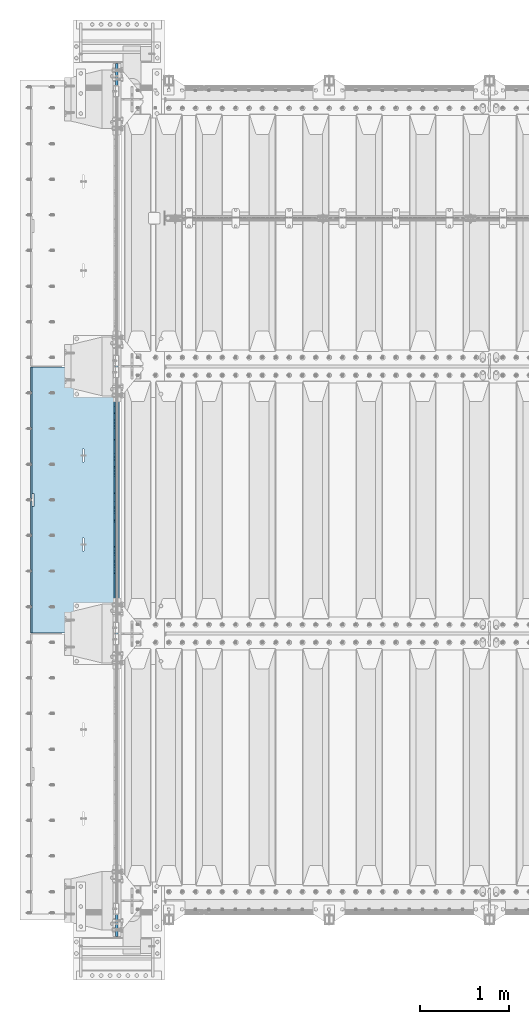
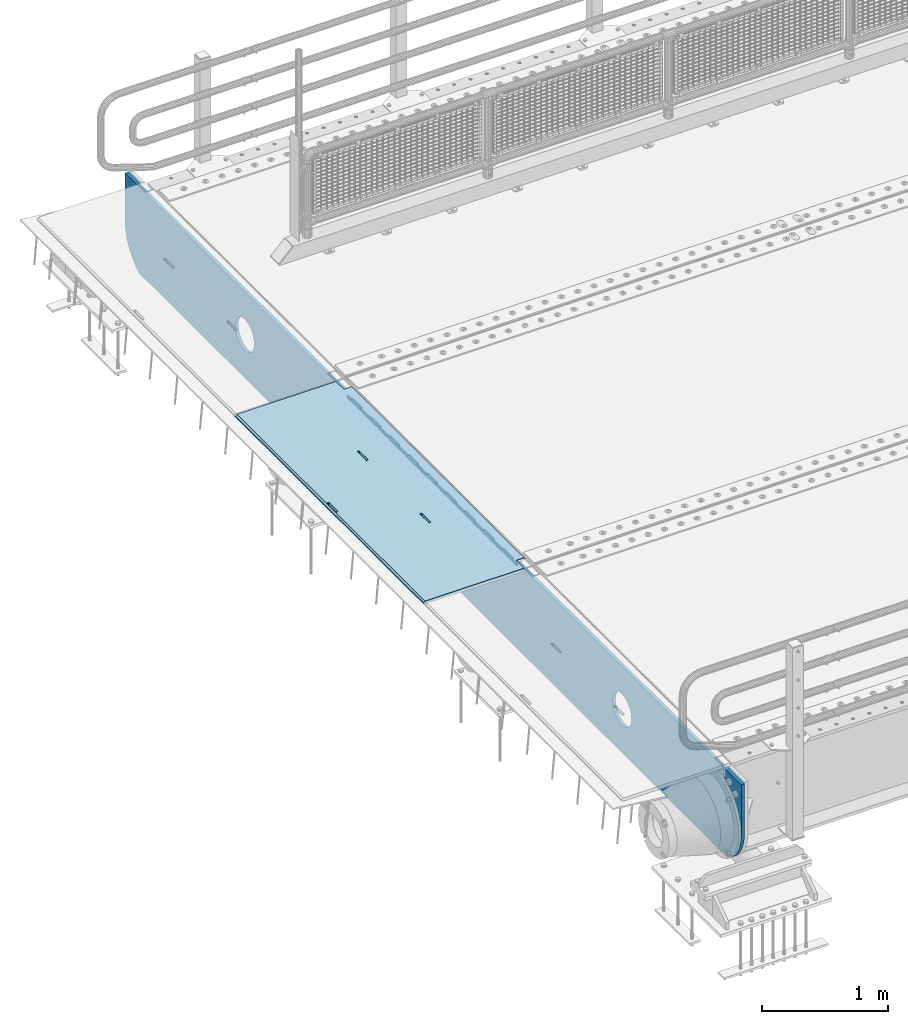
# One storey, part 170 of 219: 3 plates.
"""IFC2X3 building model written with IfcOpenShell, lengths in millimetres."""

import ifcopenshell
import ifcopenshell.guid

model = None  # the IFC model being written
_history = None  # IfcOwnerHistory: only IFC2X3 demands one
_inside = {}  # id of a spatial element -> (the spatial element, [elements in it])
_under = {}  # id of a project, library or spatial element -> (it, [spatial elements below it])
_declared = {}  # id of a project -> (the project, [libraries it declares])
_typed = {}  # id of a type object -> (the type object, [elements of that type])
_made_of = {}  # id of a material, layer set ... -> (it, [elements and type objects made of it])


def new_model(schema):
    """Start an empty IFC model of exactly this schema.

    Asked for "IFC4X3", IfcOpenShell would pick the latest addendum, in which some entities
    have other attributes; the version numbers below select the first issue.
    IFC2X3 requires an IfcOwnerHistory on every rooted entity: one is made here for all.
    """
    global model, _history
    if schema == "IFC4X3":
        model = ifcopenshell.file(schema_version=(4, 3, 0, 0))
    else:
        model = ifcopenshell.file(schema=schema)
    _inside.clear()
    _under.clear()
    _declared.clear()
    _typed.clear()
    _made_of.clear()
    _history = None
    if model.schema == "IFC2X3":
        org = make("IfcOrganization", Name="unknown")
        user = make(
            "IfcPersonAndOrganization",
            ThePerson=make("IfcPerson", FamilyName="unknown"),
            TheOrganization=org,
        )
        app = make(
            "IfcApplication",
            ApplicationDeveloper=org,
            Version="unknown",
            ApplicationFullName="unknown",
            ApplicationIdentifier="unknown",
        )
        _history = make(
            "IfcOwnerHistory",
            OwningUser=user,
            OwningApplication=app,
            ChangeAction="ADDED",
            CreationDate=0,
        )
    return model


def make(cls, **values):
    """One entity of the class cls with the attributes given. An attribute that is None is left unset."""
    return model.create_entity(
        cls, **{name: value for name, value in values.items() if value is not None}
    )


def rooted(cls, **values):
    """An entity with a GlobalId (a new one), such as an element, a storey or a relation."""
    return make(cls, GlobalId=ifcopenshell.guid.new(), OwnerHistory=_history, **values)


def si_unit(unit_type, name, prefix=None):
    """IfcSIUnit, for example si_unit("LENGTHUNIT", "METRE", prefix="MILLI")."""
    return make("IfcSIUnit", UnitType=unit_type, Prefix=prefix, Name=name)


def assignment(units):
    """IfcUnitAssignment: the units of a project."""
    return None if units is None else make("IfcUnitAssignment", Units=units)


def point(xyz):
    """IfcCartesianPoint."""
    return None if xyz is None else make("IfcCartesianPoint", Coordinates=xyz)


def direction(xyz):
    """IfcDirection."""
    return None if xyz is None else make("IfcDirection", DirectionRatios=xyz)


def frame(location, z_axis=None, x_axis=None):
    """IfcAxis2Placement3D, a coordinate frame: its origin and axes. An axis left out is left unset."""
    return make(
        "IfcAxis2Placement3D",
        Location=point(location),
        Axis=direction(z_axis),
        RefDirection=direction(x_axis),
    )


def origin_with_axes():
    """The frame at (0, 0, 0) with the z axis (0, 0, 1) and the x axis (1, 0, 0) written out."""
    return frame((0.0, 0.0, 0.0), z_axis=(0.0, 0.0, 1.0), x_axis=(1.0, 0.0, 0.0))


def place(relative_to, where):
    """IfcLocalPlacement: puts the frame where relative to a parent placement (None: the world)."""
    return make(
        "IfcLocalPlacement", PlacementRelTo=relative_to, RelativePlacement=where
    )


def context(
    kind, dimensions, precision=None, world=None, true_north=None, identifier=None
):
    """IfcGeometricRepresentationContext, for example the 3D "Model" context."""
    return make(
        "IfcGeometricRepresentationContext",
        ContextIdentifier=identifier,
        ContextType=kind,
        CoordinateSpaceDimension=dimensions,
        Precision=precision,
        WorldCoordinateSystem=world,
        TrueNorth=true_north,
    )


def subcontext(parent, identifier, kind, view, scale=None):
    """IfcGeometricRepresentationSubContext, for example "Body" below "Model"."""
    return make(
        "IfcGeometricRepresentationSubContext",
        ContextIdentifier=identifier,
        ContextType=kind,
        ParentContext=parent,
        TargetScale=scale,
        TargetView=view,
    )


def project(units=None, contexts=None):
    """IfcProject with its units and contexts."""
    return rooted(
        "IfcProject",
        Name="project",
        RepresentationContexts=contexts,
        UnitsInContext=assignment(units),
    )


def spatial(cls, under=None, at=None, **own):
    """A site, building, storey or space (cls), placed at a placement, below another one or the project."""
    s = rooted(cls, ObjectPlacement=at, **own)
    if under is not None:
        _under.setdefault(under.id(), (under, []))[1].append(s)
    return s


def faces_of(points, faces, orient=None, outer=None):
    """IfcFace entities. A face is a list of loops; a loop is a list of indices into points, from 0.

    orient and outer hold one flag for each loop. By default every Orientation is true, the
    first loop of a face is its IfcFaceOuterBound and the others are IfcFaceBound.
    """
    made = []
    for i, loops in enumerate(faces):
        bounds = []
        for j, loop in enumerate(loops):
            is_outer = j == 0 if outer is None else outer[i][j]
            bounds.append(
                make(
                    "IfcFaceOuterBound" if is_outer else "IfcFaceBound",
                    Bound=make("IfcPolyLoop", Polygon=[points[k] for k in loop]),
                    Orientation=True if orient is None else orient[i][j],
                )
            )
        made.append(make("IfcFace", Bounds=bounds))
    return made


def faceted_brep(points, faces, orient=None, outer=None, voids=None):
    """IfcFacetedBrep: a solid bounded by flat faces; with voids (closed shells), ...WithVoids."""
    shared = [point(p) for p in points]
    hull = make("IfcClosedShell", CfsFaces=faces_of(shared, faces, orient, outer))
    if voids is None:
        return make("IfcFacetedBrep", Outer=hull)
    return make(
        "IfcFacetedBrepWithVoids",
        Outer=hull,
        Voids=[
            make(cls, CfsFaces=faces_of(shared, fs, o, b)) for cls, fs, o, b in voids
        ],
    )


def shape(context_of_items, identifier, shape_type, items):
    """IfcShapeRepresentation: the items that make up one representation, for example the "Body"."""
    return make(
        "IfcShapeRepresentation",
        ContextOfItems=context_of_items,
        RepresentationIdentifier=identifier,
        RepresentationType=shape_type,
        Items=items,
    )


def material(Name=None, Category=None):
    """IfcMaterial."""
    return make("IfcMaterial", Name=Name, Category=Category)


def made_of(thing, what):
    """Note that an element or type object is made of a material, layer set ...; save() writes the relation."""
    if what is not None:
        _made_of.setdefault(what.id(), (what, []))[1].append(thing)
    return thing


def type_object(cls, material=None, **own):
    """A type object (cls), such as IfcWallType, which elements share."""
    return made_of(rooted(cls, **own), material)


def element(
    cls,
    number,
    at=None,
    inside=None,
    cuts=None,
    type_object=None,
    material=None,
    context=None,
    identifier="Body",
    shape_type=None,
    held_by="IfcProductDefinitionShape",
    body=None,
    shapes=None,
    **own,
):
    """One element of the class cls, such as IfcWall. Its Tag is "e" and its number.

    at: its placement. inside: the storey or other place that contains it. cuts: it is an
    opening in that element (IfcRelVoidsElement). A single representation is given by context,
    identifier, shape_type and body (its items); several are given by shapes. held_by: the class
    of the entity that holds the representations. save() writes the other relations.
    """
    e = rooted(cls, Tag="e%d" % number, ObjectPlacement=at, **own)
    if body is not None:
        shapes = [shape(context, identifier, shape_type, body)]
    if shapes is not None:
        e.Representation = make(held_by, Representations=shapes)
    if inside is not None:
        _inside.setdefault(inside.id(), (inside, []))[1].append(e)
    if cuts is not None:
        rooted(
            "IfcRelVoidsElement", RelatingBuildingElement=cuts, RelatedOpeningElement=e
        )
    if type_object is not None:
        _typed.setdefault(type_object.id(), (type_object, []))[1].append(e)
    return made_of(e, material)


def aggregate(whole, parts):
    """IfcRelAggregates: a whole, such as a stair, and the parts it consists of."""
    return rooted("IfcRelAggregates", RelatingObject=whole, RelatedObjects=parts)


def save(model, path):
    """Write the relations noted so far, then the file.

    IfcRelAggregates (storeys below a building ...), IfcRelContainedInSpatialStructure (elements
    in a storey), IfcRelDefinesByType, IfcRelAssociatesMaterial and IfcRelDeclares: one each for
    every whole, place, type object, material and project.
    """
    for whole, parts in _under.values():
        aggregate(whole, parts)
    for where, things in _inside.values():
        rooted(
            "IfcRelContainedInSpatialStructure",
            RelatedElements=things,
            RelatingStructure=where,
        )
    for kind, things in _typed.values():
        rooted("IfcRelDefinesByType", RelatedObjects=things, RelatingType=kind)
    for what, things in _made_of.values():
        rooted("IfcRelAssociatesMaterial", RelatedObjects=things, RelatingMaterial=what)
    for by, libraries in _declared.values():
        rooted("IfcRelDeclares", RelatingContext=by, RelatedDefinitions=libraries)
    model.write(path)


model = new_model("IFC2X3")

# Units and contexts
model_context = context("Model", 3, precision=1e-05, world=origin_with_axes())
body_context = subcontext(model_context, "Body", "Model", "MODEL_VIEW")
ifc_project = project(units=[si_unit("LENGTHUNIT", "METRE", prefix="MILLI"), si_unit("AREAUNIT", "SQUARE_METRE"), si_unit("VOLUMEUNIT", "CUBIC_METRE"), si_unit("MASSUNIT", "GRAM", prefix="KILO"), si_unit("TIMEUNIT", "SECOND"), si_unit("PLANEANGLEUNIT", "RADIAN"), si_unit("SOLIDANGLEUNIT", "STERADIAN"), si_unit("THERMODYNAMICTEMPERATUREUNIT", "DEGREE_CELSIUS"), si_unit("LUMINOUSINTENSITYUNIT", "LUMEN")], contexts=[model_context])

# Site, building, storey
site_placement = place(None, origin_with_axes())
site = spatial("IfcSite", under=ifc_project, at=site_placement, CompositionType="ELEMENT")
building_placement = place(site_placement, origin_with_axes())
building = spatial("IfcBuilding", under=site, at=building_placement, Name="Standard", CompositionType="ELEMENT")
storey_placement = place(building_placement, origin_with_axes())
storey = spatial("IfcBuildingStorey", under=building, at=storey_placement, Name="Undefined", CompositionType="ELEMENT", Elevation=0.0)

# Plates
ifc_material = material(Name="STEEL/S355N")
plate_type_1 = type_object("IfcPlateType", PredefinedType="NOTDEFINED")
plate_1_placement = place(storey_placement, frame((-57.5, 29845.0000994083, -36.0014545213866), z_axis=(0.0, -0.999999999987744, -4.95099999993769e-06), x_axis=(0.0, 4.95100000930963e-06, -0.999999999987744)))
element("IfcPlate", 1, at=plate_1_placement, inside=storey, type_object=plate_type_1, material=ifc_material, context=body_context, shape_type="Brep", body=[
    faceted_brep([(0.0, -7.49999999999999, 0.0), (-1.24849464100407e-10, -7.5, 70.0000000000036), (-1.24849464100407e-10, 7.5, 70.0000000000036), (0.0, 7.5, 0.0), (-14.9899997711175, -7.5, 70.0000000000036), (-14.9899997711175, 7.5, 70.0000000000036), (-14.9899997711161, -7.5, 220.0), (-14.9899997711161, 7.5, 220.0), (-3.90834031804843e-10, -7.5, 220.000000000004), (-3.90834031804843e-10, 7.5, 220.000000000004), (-6.56818599509279e-10, -7.5, 370.0), (-6.56818599509279e-10, 7.5, 370.0), (-14.9899997711147, -7.5, 370.000000000004), (-14.9899997711147, 7.5, 370.000000000004), (-14.9899997711133, -7.5, 520.000000000004), (-14.9899997711133, 7.5, 520.000000000004), (-9.24629262044618e-10, -7.5, 520.000000000004), (-9.24629262044618e-10, 7.5, 520.000000000004), (-1.1906067243217e-09, -7.5, 670.000000000004), (-1.1906067243217e-09, 7.5, 670.000000000004), (-14.9899997711119, -7.5, 670.0), (-14.9899997711119, 7.5, 670.0), (-14.9899997711105, -7.5, 820.000000000004), (-14.9899997711105, 7.5, 820.000000000004), (-1.45477940804994e-09, -7.5, 820.0), (-1.45477940804994e-09, 7.5, 820.0), (-1.72257585973057e-09, -7.5, 970.000000000004), (-1.72257585973057e-09, 7.5, 970.000000000004), (-14.9899997711091, -7.5, 970.000000000004), (-14.9899997711091, 7.5, 970.000000000004), (-14.9899997711077, -7.5, 1120.0), (-14.9899997711077, 7.5, 1120.0), (-1.98856753286236e-09, -7.5, 1120.0), (-1.98856753286236e-09, 7.5, 1120.0), (-2.2545521005668e-09, -7.5, 1270.0), (-2.2545521005668e-09, 7.5, 1270.0), (-14.9899997711063, -7.5, 1270.0), (-14.9899997711063, 7.5, 1270.0), (-14.9899997711049, -7.5, 1420.0), (-14.9899997711049, 7.5, 1420.0), (-2.52235565767478e-09, -7.5, 1420.0), (-2.52235565767478e-09, 7.5, 1420.0), (-2.78834733080657e-09, -7.5, 1570.0), (-2.78834733080657e-09, 7.5, 1570.0), (-14.9899997711034, -7.5, 1570.0), (-14.9899997711034, 7.5, 1570.0), (-14.989999771102, -7.5, 1720.0), (-14.989999771102, 7.5, 1720.0), (-3.05433189851101e-09, -7.5, 1720.0), (-3.05433189851101e-09, 7.5, 1720.0), (-3.32212835019163e-09, -7.5, 1870.0), (-3.32212835019163e-09, 7.5, 1870.0), (-14.9899997711006, -7.5, 1870.0), (-14.9899997711006, 7.5, 1870.0), (-14.9899997710992, -7.5, 2020.0), (-14.9899997710992, 7.5, 2020.0), (-3.58812002332343e-09, -7.5, 2020.0), (-3.58812002332343e-09, 7.5, 2020.0), (-3.85410459102786e-09, -7.5, 2170.0), (-3.85410459102786e-09, 7.5, 2170.0), (-14.9899997710978, -7.5, 2170.0), (-14.9899997710978, 7.5, 2170.0), (-14.9899997710964, -7.5, 2320.0), (-14.9899997710964, 7.5, 2320.0), (-4.12190814813584e-09, -7.5, 2320.0), (-4.12190814813584e-09, 7.5, 2320.0), (-4.38789271584028e-09, -7.5, 2470.0), (-4.38789271584028e-09, 7.5, 2470.0), (-14.9999999999768, -7.5, 2470.0), (-14.9999999999768, 7.5, 2470.0), (-14.9899997710936, -7.5, 2620.0), (-14.9899997710936, 7.5, 2620.0), (-4.65388438897207e-09, -7.5, 2620.0), (-4.65388438897207e-09, 7.5, 2620.0), (-4.77873385307248e-09, -7.5, 2690.0), (-4.77873385307248e-09, 7.5, 2690.0), (25.0100002289071, -7.5, 2690.0), (25.0100002289071, 7.5, 2690.0), (25.0, -7.49999999999999, 0.0), (25.0, 7.5, 0.0)], [[[0, 1, 2, 3]], [[1, 4, 5, 2]], [[4, 6, 7, 5]], [[6, 8, 9, 7]], [[8, 10, 11, 9]], [[10, 12, 13, 11]], [[12, 14, 15, 13]], [[14, 16, 17, 15]], [[16, 18, 19, 17]], [[18, 20, 21, 19]], [[20, 22, 23, 21]], [[22, 24, 25, 23]], [[24, 26, 27, 25]], [[26, 28, 29, 27]], [[28, 30, 31, 29]], [[30, 32, 33, 31]], [[32, 34, 35, 33]], [[34, 36, 37, 35]], [[36, 38, 39, 37]], [[38, 40, 41, 39]], [[40, 42, 43, 41]], [[42, 44, 45, 43]], [[44, 46, 47, 45]], [[46, 48, 49, 47]], [[48, 50, 51, 49]], [[50, 52, 53, 51]], [[52, 54, 55, 53]], [[54, 56, 57, 55]], [[56, 58, 59, 57]], [[58, 60, 61, 59]], [[60, 62, 63, 61]], [[62, 64, 65, 63]], [[64, 66, 67, 65]], [[66, 68, 69, 67]], [[68, 70, 71, 69]], [[70, 72, 73, 71]], [[72, 74, 75, 73]], [[74, 76, 77, 75]], [[76, 78, 79, 77]], [[78, 0, 3, 79]], [[5, 7, 9, 11, 13, 15, 17, 19, 21, 23, 25, 27, 29, 31, 33, 35, 37, 39, 41, 43, 45, 47, 49, 51, 53, 55, 57, 59, 61, 63, 65, 67, 69, 71, 73, 75, 77, 79, 3, 2]], [[78, 76, 74, 72, 70, 68, 66, 64, 62, 60, 58, 56, 54, 52, 50, 48, 46, 44, 42, 40, 38, 36, 34, 32, 30, 28, 26, 24, 22, 20, 18, 16, 14, 12, 10, 8, 6, 4, 1, 0]]]),
])
plate_type_2 = type_object("IfcPlateType", PredefinedType="NOTDEFINED")
plate_2_placement = place(storey_placement, frame((-5.00375433032989, 29994.9999261728, -1.00001208605641), z_axis=(0.0, -0.999999999987744, -4.95099999993769e-06), x_axis=(-0.999999999879068, -1.00000022172504e-09, -1.55519999981193e-05)))
element("IfcPlate", 2, at=plate_2_placement, inside=storey, type_object=plate_type_2, material=ifc_material, context=body_context, shape_type="Brep", body=[
    faceted_brep([(-0.000111589569153914, -5.71507077586908e-05, 2865.00000504128), (15.0002388791539, 15.0, 2865.00008049106), (15.000010422308, 15.0, 125.000079348178), (-0.000225737458036335, 5.71560140520955e-05, 125.000003632576), (999.996459960937, 4.99999999999999, 3.63797880709171e-12), (984.996459960937, 15.0, 3.63797880709171e-12), (984.996459730713, 15.0, 2990.0), (999.996459730713, 5.0, 2990.00000000001), (999.996459730713, -5.0, 2990.00000000001), (984.99645973052, -15.0, 2990.0), (984.996459961366, -15.0, 0.0), (999.996459960937, -5.0, 3.63797880709171e-12), (959.999522276416, -15.0000000031848, 1560.00000000859), (959.999522276416, 15.0, 1560.00000000859), (960.488957113226, 15.0, 1563.09016995233), (960.488957113226, -15.0000000031888, 1563.09016995234), (961.909352332213, 15.0, 1565.87785253151), (961.909352332213, -15.0000000032008, 1565.87785253151), (964.121669752867, 15.0, 1568.09016995233), (964.121669752867, -15.0000000032195, 1568.09016995234), (966.909352331933, 15.0, 1569.51056517154), (966.909352331933, -15.0000000032433, 1569.51056517154), (969.999522275633, 15.0, 1570.00000000859), (969.999522275633, -15.0000000032698, 1570.00000000859), (973.089692219423, 15.0, 1569.51056517153), (973.089692219423, -15.0000000032963, 1569.51056517154), (975.877374798709, 15.0, 1568.09016995233), (975.877374798709, -15.0000000033202, 1568.09016995233), (978.089692219705, 15.0, 1565.87785253151), (978.089692219705, -15.0000000033393, 1565.87785253151), (979.51008743912, 15.0, 1563.09016995233), (979.51008743912, -15.0000000033517, 1563.09016995233), (979.999522276404, 15.0, 1560.00000000857), (979.999522276404, -15.0000000033561, 1560.00000000857), (979.999522286274, 15.0, 1430.00000000857), (979.999522286274, -15.0000000033655, 1430.00000000857), (979.510087449461, 15.0, 1426.90983006483), (979.510087449461, -15.0000000033615, 1426.90983006483), (978.089692230473, 15.0, 1424.12214748566), (978.089692230472, -15.0000000033495, 1424.12214748566), (975.877374809819, 15.0, 1421.90983006484), (975.877374809819, -15.0000000033307, 1421.90983006484), (973.089692230754, 15.0, 1420.48943484563), (973.089692230754, -15.0000000033069, 1420.48943484563), (969.999522287207, 15.0, 1420.00000000859), (969.999522287207, -15.0000000032805, 1420.00000000859), (966.90935234342, 15.0, 1420.48943484564), (966.90935234342, -15.000000003254, 1420.48943484564), (964.121669764135, 15.0, 1421.90983006484), (964.121669764135, -15.00000000323, 1421.90983006484), (961.90935234314, 15.0, 1424.12214748566), (961.90935234314, -15.0000000032109, 1424.12214748566), (960.488957123723, 15.0, 1426.90983006484), (960.488957123723, -15.0000000031986, 1426.90983006484), (959.999522286436, 15.0, 1430.00000000859), (959.999522286436, -15.0000000031942, 1430.00000000859), (-0.000461899023639134, -14.9999999925605, 124.999928197289), (-0.000462055621302859, -14.9999999889596, 2864.99992960658), (75.0002624101966, 15.0, 125.000080471753), (74.9997898801964, -15.0, 124.999929601756), (74.999782061445, -15.0, 0.0), (75.0002485914438, 15.0, 0.0), (75.0005015105598, 15.0, 2990.0), (75.0000289805597, -15.0, 2990.0), (75.000491135538, 15.0, 2865.00008054909), (75.0000186055379, -14.999999997918, 2864.99992967908), (395.488957121483, -15.0, 1926.90983006551), (395.488957121483, 15.0, 1926.90983006551), (394.999522284197, 15.0, 1930.00000000926), (394.999522284197, -15.0, 1930.00000000927), (396.9093523409, -15.0, 1924.12214748633), (396.9093523409, 15.0, 1924.12214748634), (399.121669761895, -15.0, 1921.90983006551), (399.121669761895, 15.0, 1921.90983006551), (401.90935234118, -15.0, 1920.48943484631), (401.90935234118, 15.0, 1920.48943484631), (404.999522284967, -15.0, 1920.00000000926), (404.999522284967, 15.0, 1920.00000000926), (408.089692228539, -15.0, 1920.48943484631), (408.089692228539, 15.0, 1920.48943484631), (410.877374807603, -15.0, 1921.90983006551), (410.877374807603, 15.0, 1921.90983006551), (413.089692228257, -15.0, 1924.12214748633), (413.089692228257, 15.0, 1924.12214748633), (414.510087447246, -15.0, 1926.90983006551), (414.510087447246, 15.0, 1926.9098300655), (414.999522284058, -15.0, 1930.00000000926), (414.999522284058, 15.0, 1930.00000000925), (414.999522274167, -15.0, 2060.00000000926), (414.999522274167, 15.0, 2060.00000000925), (414.510087436882, -15.0, 2063.090169953), (414.510087436882, 15.0, 2063.090169953), (413.089692217466, -15.0, 2065.87785253218), (413.089692217466, 15.0, 2065.87785253218), (410.877374796471, -15.0, 2068.09016995301), (410.877374796471, 15.0, 2068.09016995301), (408.089692217185, -15.0, 2069.51056517222), (408.089692217185, 15.0, 2069.51056517222), (404.999522273396, -15.0, 2070.00000000926), (404.999522273396, 15.0, 2070.00000000926), (401.909352329694, -15.0, 2069.51056517222), (401.909352329694, 15.0, 2069.51056517221), (399.121669750628, -15.0, 2068.09016995301), (399.121669750628, 15.0, 2068.09016995302), (396.909352329974, -15.0, 2065.87785253219), (396.909352329974, 15.0, 2065.87785253219), (395.488957110987, -15.0, 2063.09016995301), (395.488957110987, 15.0, 2063.09016995301), (394.999522274176, -15.0, 2060.00000000927), (394.999522274176, 15.0, 2060.00000000926), (395.48895718799, -15.0, 1063.09016995166), (396.909352406977, -15.0, 1065.87785253083), (399.121669827631, -15.0, 1068.09016995166), (401.909352406696, -15.0, 1069.51056517086), (404.999522350398, -15.0, 1070.00000000791), (408.089692294187, -15.0, 1069.51056517087), (410.877374873474, -15.0, 1068.09016995166), (413.08969229447, -15.0, 1065.87785253083), (414.510087513886, -15.0, 1063.09016995165), (414.99952235117, -15.0, 1060.0000000079), (414.999522361062, -15.0, 930.000000007905), (414.510087524249, -15.0, 926.909830064156), (413.089692305261, -15.0, 924.122147484984), (410.877374884607, -15.0, 921.90983006416), (408.089692305543, -15.0, 920.489434844963), (404.999522361971, -15.0, 920.000000007909), (401.909352418184, -15.0, 920.489434844963), (399.121669838899, -15.0, 921.90983006416), (396.909352417904, -15.0, 924.122147484984), (395.488957198487, -15.0, 926.90983006416), (394.9995223612, -15.0, 930.000000007916), (394.99952235118, -15.0, 1060.00000000791), (396.909352417904, 15.0, 924.122147484988), (395.488957198487, 15.0, 926.90983006416), (399.121669838899, 15.0, 921.909830064164), (401.909352418184, 15.0, 920.48943484496), (404.999522361971, 15.0, 920.000000007905), (408.089692305543, 15.0, 920.48943484496), (410.877374884607, 15.0, 921.90983006416), (413.089692305261, 15.0, 924.122147484981), (414.510087524249, 15.0, 926.909830064153), (414.999522361062, 15.0, 930.000000007902), (414.99952235117, 15.0, 1060.0000000079), (414.510087513886, 15.0, 1063.09016995165), (413.08969229447, 15.0, 1065.87785253083), (410.877374873474, 15.0, 1068.09016995166), (408.089692294187, 15.0, 1069.51056517086), (404.999522350398, 15.0, 1070.00000000791), (401.909352406696, 15.0, 1069.51056517086), (399.121669827631, 15.0, 1068.09016995166), (396.909352406977, 15.0, 1065.87785253083), (395.48895718799, 15.0, 1063.09016995165), (394.99952235118, 15.0, 1060.00000000791), (394.9995223612, 15.0, 930.000000007913)], [[[0, 1, 2, 3]], [[4, 5, 6, 7]], [[8, 9, 10, 11]], [[12, 13, 14, 15]], [[15, 14, 16, 17]], [[17, 16, 18, 19]], [[19, 18, 20, 21]], [[21, 20, 22, 23]], [[23, 22, 24, 25]], [[25, 24, 26, 27]], [[27, 26, 28, 29]], [[29, 28, 30, 31]], [[31, 30, 32, 33]], [[33, 32, 34, 35]], [[35, 34, 36, 37]], [[37, 36, 38, 39]], [[39, 38, 40, 41]], [[41, 40, 42, 43]], [[43, 42, 44, 45]], [[45, 44, 46, 47]], [[47, 46, 48, 49]], [[49, 48, 50, 51]], [[51, 50, 52, 53]], [[53, 52, 54, 55]], [[55, 54, 13, 12]], [[56, 57, 0, 3]], [[58, 59, 56, 3, 2]], [[60, 59, 58, 61]], [[11, 10, 60, 61, 5, 4]], [[8, 11, 4, 7]], [[62, 63, 9, 8, 7, 6]], [[63, 62, 64, 65]], [[57, 65, 64, 1, 0]], [[66, 67, 68, 69]], [[70, 71, 67, 66]], [[72, 73, 71, 70]], [[74, 75, 73, 72]], [[76, 77, 75, 74]], [[78, 79, 77, 76]], [[80, 81, 79, 78]], [[82, 83, 81, 80]], [[84, 85, 83, 82]], [[86, 87, 85, 84]], [[88, 89, 87, 86]], [[90, 91, 89, 88]], [[92, 93, 91, 90]], [[94, 95, 93, 92]], [[96, 97, 95, 94]], [[98, 99, 97, 96]], [[100, 101, 99, 98]], [[102, 103, 101, 100]], [[104, 105, 103, 102]], [[106, 107, 105, 104]], [[108, 109, 107, 106]], [[69, 68, 109, 108]], [[63, 65, 57, 56, 59, 60, 10, 9], [15, 17, 19, 21, 23, 25, 27, 29, 31, 33, 35, 37, 39, 41, 43, 45, 47, 49, 51, 53, 55, 12], [110, 111, 112, 113, 114, 115, 116, 117, 118, 119, 120, 121, 122, 123, 124, 125, 126, 127, 128, 129, 130, 131], [106, 104, 102, 100, 98, 96, 94, 92, 90, 88, 86, 84, 82, 80, 78, 76, 74, 72, 70, 66, 69, 108]], [[128, 132, 133, 129]], [[127, 134, 132, 128]], [[126, 135, 134, 127]], [[125, 136, 135, 126]], [[124, 137, 136, 125]], [[123, 138, 137, 124]], [[122, 139, 138, 123]], [[121, 140, 139, 122]], [[120, 141, 140, 121]], [[119, 142, 141, 120]], [[118, 143, 142, 119]], [[117, 144, 143, 118]], [[116, 145, 144, 117]], [[115, 146, 145, 116]], [[114, 147, 146, 115]], [[113, 148, 147, 114]], [[112, 149, 148, 113]], [[111, 150, 149, 112]], [[110, 151, 150, 111]], [[131, 152, 151, 110]], [[130, 153, 152, 131]], [[129, 133, 153, 130]], [[64, 62, 6, 5, 61, 58, 2, 1], [50, 48, 46, 44, 42, 40, 38, 36, 34, 32, 30, 28, 26, 24, 22, 20, 18, 16, 14, 13, 54, 52], [132, 134, 135, 136, 137, 138, 139, 140, 141, 142, 143, 144, 145, 146, 147, 148, 149, 150, 151, 152, 153, 133], [71, 73, 75, 77, 79, 81, 83, 85, 87, 89, 91, 93, 95, 97, 99, 101, 103, 105, 107, 109, 68, 67]]]),
])
plate_type_3 = type_object("IfcPlateType", PredefinedType="NOTDEFINED")
plate_3_placement = place(storey_placement, frame((-35.0, 23600.0, -36.0000011217838), z_axis=(0.0, 1.0, 0.0), x_axis=(0.0, 0.0, -1.0)))
element("IfcPlate", 3, at=plate_3_placement, inside=storey, type_object=plate_type_3, material=ifc_material, context=body_context, shape_type="Brep", body=[
    faceted_brep([(449.263564598338, -15.0, 2047.11778936561), (449.263564598338, 15.0, 2047.11778936561), (477.402531099467, 15.0, 2038.58192701299), (477.402531099467, -15.0, 2038.58192701299), (503.335551114475, 15.0, 2024.72043882608), (503.335551114475, -15.0, 2024.72043882608), (526.06603322759, 15.0, 2006.06601402229), (526.06603322759, -15.0, 2006.06601402229), (544.720457758607, 15.0, 1983.33553168533), (544.720457758607, -15.0, 1983.33553168533), (558.58194563432, 15.0, 1957.40251150398), (558.58194563432, -15.0, 1957.40251150398), (567.117807649278, 15.0, 1929.26354490042), (567.117807649278, -15.0, 1929.26354490042), (570.000015413212, 15.0, 1899.99999658071), (570.000015413212, -15.0, 1899.99999658071), (567.117807298115, 15.0, 1870.73644829558), (567.117807298115, -15.0, 1870.73644829558), (558.581944945489, 15.0, 1842.59748179446), (558.581944945489, -15.0, 1842.59748179446), (544.72045675858, 15.0, 1816.66446177944), (544.72045675858, -15.0, 1816.66446177944), (526.066031954798, 15.0, 1793.93397966633), (526.066031954798, -15.0, 1793.93397966633), (503.335549617829, 15.0, 1775.27955513532), (503.335549617829, -15.0, 1775.27955513532), (477.402529436484, 15.0, 1761.4180672596), (477.402529436484, -15.0, 1761.4180672596), (449.263562832924, 15.0, 1752.88220524464), (449.263562832924, -15.0, 1752.88220524464), (420.000014513212, 15.0, 1749.99999748071), (420.000014513212, -15.0, 1749.99999748071), (390.736466228086, 15.0, 1752.8822055958), (390.736466228086, -15.0, 1752.8822055958), (362.597499726957, 15.0, 1761.41806794843), (362.597499726957, -15.0, 1761.41806794843), (336.664479711949, 15.0, 1775.27955613534), (336.664479711949, -15.0, 1775.27955613534), (313.933997598833, 15.0, 1793.93398093912), (313.933997598833, -15.0, 1793.93398093912), (295.279573067817, 15.0, 1816.66446327609), (295.279573067817, -15.0, 1816.66446327609), (281.418085192103, 15.0, 1842.59748345744), (281.418085192103, -15.0, 1842.59748345744), (272.882223177146, 15.0, 1870.73645006099), (272.882223177146, -15.0, 1870.73645006099), (270.000015413212, 15.0, 1899.99999838071), (270.000015413212, -15.0, 1899.99999838071), (272.882223528308, 15.0, 1929.26354666584), (272.882223528308, -15.0, 1929.26354666584), (281.418085880934, 15.0, 1957.40251316696), (281.418085880934, -15.0, 1957.40251316696), (295.279574067843, 15.0, 1983.33553318197), (295.279574067843, -15.0, 1983.33553318197), (313.933998871626, 15.0, 2006.06601529508), (313.933998871626, -15.0, 2006.06601529508), (336.664481208594, 15.0, 2024.7204398261), (336.664481208594, -15.0, 2024.7204398261), (362.59750138994, 15.0, 2038.58192770182), (362.59750138994, -15.0, 2038.58192770182), (390.736467993499, 15.0, 2047.11778971678), (390.736467993499, -15.0, 2047.11778971678), (420.000016313212, 15.0, 2049.99999748071), (420.000016313212, -15.0, 2049.99999748071), (-1.00212931641863e-06, 15.0, 9800.0), (-1.00212931641863e-06, -15.0, 9800.0), (479.000057668268, -15.0, 9799.99999712676), (479.000057638257, 15.0, 9800.0), (0.0, -15.0, 0.0), (0.0, 15.0, 0.0), (478.999999998661, 15.0, 3.63797880709171e-12), (478.999999998661, -15.0, 3.63797880709171e-12), (527.214672103509, 15.0, 2.91645036353293), (527.214672103509, -15.0, 2.91645036353293), (574.726265715988, 15.0, 11.623273032008), (574.726265715988, -15.0, 11.623273032008), (620.841954817566, 15.0, 25.9935029279113), (620.841954817566, -15.0, 25.9935029279113), (664.889268817663, 15.0, 45.8175897404326), (664.889268817663, -15.0, 45.8175897404326), (706.225898692239, 15.0, 70.8064536438796), (706.225898692239, -15.0, 70.8064536438796), (744.249063295727, 15.0, 100.59570073252), (744.249063295727, -15.0, 100.59570073252), (778.404299267498, 15.0, 134.750936704255), (778.404299267498, -15.0, 134.750936704255), (808.193546356196, 15.0, 172.774101307714), (808.193546356196, -15.0, 172.774101307714), (833.182410259716, 15.0, 214.110731182285), (833.182410259716, -15.0, 214.110731182285), (838.999998585997, -15.0, 227.036882190067), (838.999998585997, 15.0, 227.036882190067), (838.999940378862, 15.0, 9572.9632660323), (838.999940378862, -15.0, 9572.96326609896), (833.182425747838, 15.0, 9585.88925446581), (833.182425777838, -15.0, 9585.88925446581), (808.193562516767, 15.0, 9627.22588611668), (808.193562546767, -15.0, 9627.22588611668), (778.404315769945, 15.0, 9665.24905247718), (778.404315799945, -15.0, 9665.24905247718), (744.24907982555, 15.0, 9699.40429013417), (744.24907985555, -15.0, 9699.40429013417), (706.225914958721, 15.0, 9729.19353878752), (706.225914988721, -15.0, 9729.19353878752), (664.88928456082, 15.0, 9754.18240409127), (664.88928459082, -15.0, 9754.18240409127), (620.841969814272, 15.0, 9774.00649210158), (620.841969844272, -15.0, 9774.00649210158), (574.726279785182, 15.0, 9788.37672296127), (574.726279815182, -15.0, 9788.37672296127), (527.214685110275, 15.0, 9797.0835463353), (527.214685140275, -15.0, 9797.0835463353), (390.736498855293, -15.0, 8047.11778971678), (390.736498855293, 15.0, 8047.11778971678), (420.000047175005, 15.0, 8049.99999748071), (420.000047175005, -15.0, 8049.99999748071), (362.597532251734, -15.0, 8038.58192770182), (362.597532251734, 15.0, 8038.58192770182), (336.664512070388, -15.0, 8024.7204398261), (336.664512070388, 15.0, 8024.7204398261), (313.934029733419, -15.0, 8006.06601529508), (313.934029733419, 15.0, 8006.06601529508), (295.279604929637, -15.0, 7983.33553318197), (295.279604929637, 15.0, 7983.33553318197), (281.418116742727, -15.0, 7957.40251316696), (281.418116742727, 15.0, 7957.40251316696), (272.882254390102, -15.0, 7929.26354666584), (272.882254390102, 15.0, 7929.26354666584), (270.000046275005, -15.0, 7899.99999838071), (270.000046275005, 15.0, 7899.99999838071), (272.88225403894, -15.0, 7870.73645006099), (272.88225403894, 15.0, 7870.73645006099), (281.418116053897, -15.0, 7842.59748345744), (281.418116053897, 15.0, 7842.59748345744), (295.27960392961, -15.0, 7816.66446327609), (295.27960392961, 15.0, 7816.66446327609), (313.934028460627, -15.0, 7793.93398093912), (313.934028460627, 15.0, 7793.93398093912), (336.664510573743, -15.0, 7775.27955613534), (336.664510573743, 15.0, 7775.27955613534), (362.59753058875, -15.0, 7761.41806794843), (362.59753058875, 15.0, 7761.41806794843), (390.736497089879, -15.0, 7752.8822055958), (390.736497089879, 15.0, 7752.8822055958), (420.000045375005, -15.0, 7749.99999748071), (420.000045375005, 15.0, 7749.99999748071), (449.263593694718, -15.0, 7752.88220524464), (449.263593694718, 15.0, 7752.88220524464), (477.402560298277, -15.0, 7761.4180672596), (477.402560298277, 15.0, 7761.4180672596), (503.335580479623, -15.0, 7775.27955513532), (503.335580479623, 15.0, 7775.27955513532), (526.066062816592, -15.0, 7793.93397966633), (526.066062816592, 15.0, 7793.93397966633), (544.720487620374, -15.0, 7816.66446177944), (544.720487620374, 15.0, 7816.66446177944), (558.581975807283, -15.0, 7842.59748179446), (558.581975807283, 15.0, 7842.59748179446), (567.117838159909, -15.0, 7870.73644829558), (567.117838159909, 15.0, 7870.73644829558), (570.000046275006, -15.0, 7899.99999658071), (570.000046275006, 15.0, 7899.99999658071), (567.117838511071, -15.0, 7929.26354490042), (567.117838511071, 15.0, 7929.26354490042), (558.581976496114, -15.0, 7957.40251150398), (558.581976496114, 15.0, 7957.40251150398), (544.7204886204, -15.0, 7983.33553168533), (544.7204886204, 15.0, 7983.33553168533), (526.066064089384, -15.0, 8006.06601402229), (526.066064089384, 15.0, 8006.06601402229), (503.335581976268, -15.0, 8024.72043882608), (503.335581976268, 15.0, 8024.72043882608), (477.40256196126, -15.0, 8038.58192701299), (477.40256196126, 15.0, 8038.58192701299), (449.263595460131, -15.0, 8047.11778936561), (449.263595460131, 15.0, 8047.11778936561), (477.402546523754, -15.0, 5038.58192701299), (503.335566538762, -15.0, 5024.72043882608), (526.066048651878, -15.0, 5006.06601402229), (544.720473182894, -15.0, 4983.33553168533), (558.581961058607, -15.0, 4957.40251150398), (567.117823073565, -15.0, 4929.26354490042), (570.000030837499, -15.0, 4899.99999658071), (567.117822722403, -15.0, 4870.73644829558), (558.581960369777, -15.0, 4842.59748179446), (544.720472182868, -15.0, 4816.66446177944), (526.066047379085, -15.0, 4793.93397966633), (503.335565042117, -15.0, 4775.27955513532), (477.402544860771, -15.0, 4761.4180672596), (449.263578257212, -15.0, 4752.88220524464), (420.000029937499, -15.0, 4749.99999748071), (390.736481652373, -15.0, 4752.8822055958), (362.597515151244, -15.0, 4761.41806794843), (336.664495136236, -15.0, 4775.27955613534), (313.934013023121, -15.0, 4793.93398093912), (295.279588492104, -15.0, 4816.66446327609), (281.418100616391, -15.0, 4842.59748345744), (272.882238601433, -15.0, 4870.73645006099), (270.000030837499, -15.0, 4899.99999838071), (272.882238952596, -15.0, 4929.26354666584), (281.418101305221, -15.0, 4957.40251316696), (295.279589492131, -15.0, 4983.33553318197), (313.934014295913, -15.0, 5006.06601529508), (336.664496632882, -15.0, 5024.7204398261), (362.597516814228, -15.0, 5038.58192770182), (390.736483417787, -15.0, 5047.11778971678), (420.000031737499, -15.0, 5049.99999748071), (449.263580022625, -15.0, 5047.11778936561), (362.597516814228, 15.0, 5038.58192770182), (390.736483417787, 15.0, 5047.11778971678), (336.664496632882, 15.0, 5024.7204398261), (313.934014295913, 15.0, 5006.06601529508), (295.279589492131, 15.0, 4983.33553318197), (281.418101305221, 15.0, 4957.40251316696), (272.882238952596, 15.0, 4929.26354666584), (270.000030837499, 15.0, 4899.99999838071), (272.882238601433, 15.0, 4870.73645006099), (281.418100616391, 15.0, 4842.59748345744), (295.279588492104, 15.0, 4816.66446327609), (313.934013023121, 15.0, 4793.93398093912), (336.664495136236, 15.0, 4775.27955613534), (362.597515151244, 15.0, 4761.41806794843), (390.736481652373, 15.0, 4752.8822055958), (420.000029937499, 15.0, 4749.99999748071), (449.263578257212, 15.0, 4752.88220524464), (477.402544860771, 15.0, 4761.4180672596), (503.335565042117, 15.0, 4775.27955513532), (526.066047379085, 15.0, 4793.93397966633), (544.720472182868, 15.0, 4816.66446177944), (558.581960369777, 15.0, 4842.59748179446), (567.117822722403, 15.0, 4870.73644829558), (570.000030837499, 15.0, 4899.99999658071), (567.117823073565, 15.0, 4929.26354490042), (558.581961058607, 15.0, 4957.40251150398), (544.720473182894, 15.0, 4983.33553168533), (526.066048651878, 15.0, 5006.06601402229), (503.335566538762, 15.0, 5024.72043882608), (477.402546523754, 15.0, 5038.58192701299), (449.263580022625, 15.0, 5047.11778936561), (420.000031737499, 15.0, 5049.99999748071)], [[[0, 1, 2, 3]], [[3, 2, 4, 5]], [[5, 4, 6, 7]], [[7, 6, 8, 9]], [[9, 8, 10, 11]], [[11, 10, 12, 13]], [[13, 12, 14, 15]], [[15, 14, 16, 17]], [[17, 16, 18, 19]], [[19, 18, 20, 21]], [[21, 20, 22, 23]], [[23, 22, 24, 25]], [[25, 24, 26, 27]], [[27, 26, 28, 29]], [[29, 28, 30, 31]], [[31, 30, 32, 33]], [[33, 32, 34, 35]], [[35, 34, 36, 37]], [[37, 36, 38, 39]], [[39, 38, 40, 41]], [[41, 40, 42, 43]], [[43, 42, 44, 45]], [[45, 44, 46, 47]], [[47, 46, 48, 49]], [[49, 48, 50, 51]], [[51, 50, 52, 53]], [[53, 52, 54, 55]], [[55, 54, 56, 57]], [[57, 56, 58, 59]], [[59, 58, 60, 61]], [[61, 60, 62, 63]], [[63, 62, 1, 0]], [[64, 65, 66, 67]], [[68, 65, 64, 69]], [[68, 69, 70, 71]], [[71, 70, 72, 73]], [[73, 72, 74, 75]], [[75, 74, 76, 77]], [[77, 76, 78, 79]], [[79, 78, 80, 81]], [[81, 80, 82, 83]], [[83, 82, 84, 85]], [[85, 84, 86, 87]], [[87, 86, 88, 89]], [[90, 89, 88, 91]], [[90, 91, 92, 93]], [[93, 92, 94, 95]], [[95, 94, 96, 97]], [[97, 96, 98, 99]], [[99, 98, 100, 101]], [[101, 100, 102, 103]], [[103, 102, 104, 105]], [[105, 104, 106, 107]], [[107, 106, 108, 109]], [[109, 108, 110, 111]], [[66, 111, 110, 67]], [[112, 113, 114, 115]], [[116, 117, 113, 112]], [[118, 119, 117, 116]], [[120, 121, 119, 118]], [[122, 123, 121, 120]], [[124, 125, 123, 122]], [[126, 127, 125, 124]], [[128, 129, 127, 126]], [[130, 131, 129, 128]], [[132, 133, 131, 130]], [[134, 135, 133, 132]], [[136, 137, 135, 134]], [[138, 139, 137, 136]], [[140, 141, 139, 138]], [[142, 143, 141, 140]], [[144, 145, 143, 142]], [[146, 147, 145, 144]], [[148, 149, 147, 146]], [[150, 151, 149, 148]], [[152, 153, 151, 150]], [[154, 155, 153, 152]], [[156, 157, 155, 154]], [[158, 159, 157, 156]], [[160, 161, 159, 158]], [[162, 163, 161, 160]], [[164, 165, 163, 162]], [[166, 167, 165, 164]], [[168, 169, 167, 166]], [[170, 171, 169, 168]], [[172, 173, 171, 170]], [[174, 175, 173, 172]], [[115, 114, 175, 174]], [[65, 68, 71, 73, 75, 77, 79, 81, 83, 85, 87, 89, 90, 93, 95, 97, 99, 101, 103, 105, 107, 109, 111, 66], [3, 5, 7, 9, 11, 13, 15, 17, 19, 21, 23, 25, 27, 29, 31, 33, 35, 37, 39, 41, 43, 45, 47, 49, 51, 53, 55, 57, 59, 61, 63, 0], [176, 177, 178, 179, 180, 181, 182, 183, 184, 185, 186, 187, 188, 189, 190, 191, 192, 193, 194, 195, 196, 197, 198, 199, 200, 201, 202, 203, 204, 205, 206, 207], [172, 170, 168, 166, 164, 162, 160, 158, 156, 154, 152, 150, 148, 146, 144, 142, 140, 138, 136, 134, 132, 130, 128, 126, 124, 122, 120, 118, 116, 112, 115, 174]], [[204, 208, 209, 205]], [[203, 210, 208, 204]], [[202, 211, 210, 203]], [[201, 212, 211, 202]], [[200, 213, 212, 201]], [[199, 214, 213, 200]], [[198, 215, 214, 199]], [[197, 216, 215, 198]], [[196, 217, 216, 197]], [[195, 218, 217, 196]], [[194, 219, 218, 195]], [[193, 220, 219, 194]], [[192, 221, 220, 193]], [[191, 222, 221, 192]], [[190, 223, 222, 191]], [[189, 224, 223, 190]], [[188, 225, 224, 189]], [[187, 226, 225, 188]], [[186, 227, 226, 187]], [[185, 228, 227, 186]], [[184, 229, 228, 185]], [[183, 230, 229, 184]], [[182, 231, 230, 183]], [[181, 232, 231, 182]], [[180, 233, 232, 181]], [[179, 234, 233, 180]], [[178, 235, 234, 179]], [[177, 236, 235, 178]], [[176, 237, 236, 177]], [[207, 238, 237, 176]], [[206, 239, 238, 207]], [[205, 209, 239, 206]], [[108, 106, 104, 102, 100, 98, 96, 94, 92, 91, 88, 86, 84, 82, 80, 78, 76, 74, 72, 70, 69, 64, 67, 110], [58, 56, 54, 52, 50, 48, 46, 44, 42, 40, 38, 36, 34, 32, 30, 28, 26, 24, 22, 20, 18, 16, 14, 12, 10, 8, 6, 4, 2, 1, 62, 60], [208, 210, 211, 212, 213, 214, 215, 216, 217, 218, 219, 220, 221, 222, 223, 224, 225, 226, 227, 228, 229, 230, 231, 232, 233, 234, 235, 236, 237, 238, 239, 209], [117, 119, 121, 123, 125, 127, 129, 131, 133, 135, 137, 139, 141, 143, 145, 147, 149, 151, 153, 155, 157, 159, 161, 163, 165, 167, 169, 171, 173, 175, 114, 113]]]),
])

save(model, "model.ifc")
